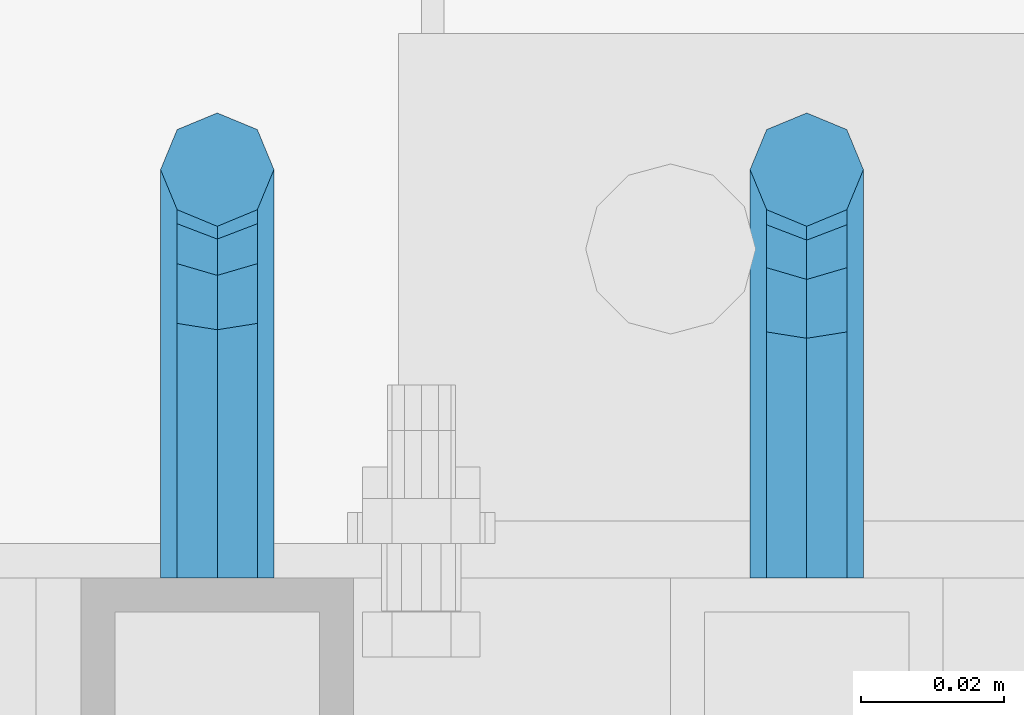
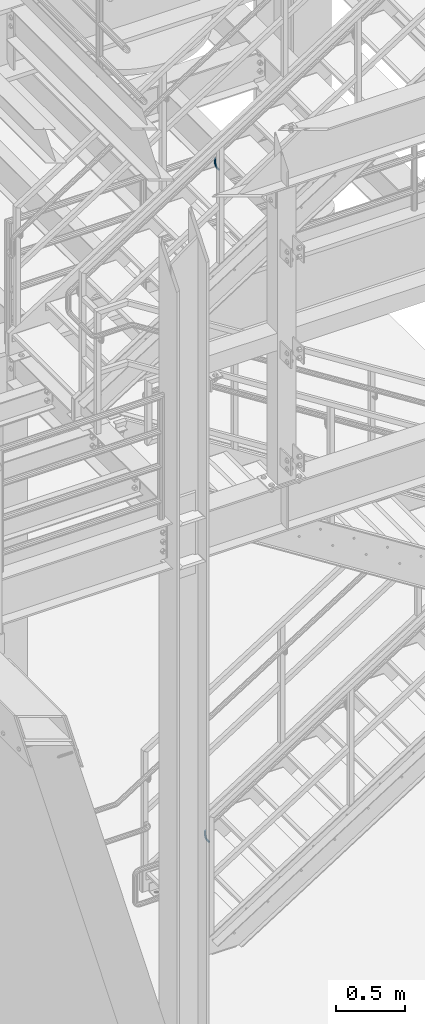
# One storey, part 1170 of 1876: 2 beams, 2 elements without a shape of their own.
"""IFC2X3 building model written with IfcOpenShell, lengths in millimetres."""

from ifc_helpers import new_model, si_unit, frame, origin_with_axes, place, context, subcontext, project, spatial, faceted_brep, material, type_object, element, aggregate, save


model = new_model("IFC2X3")

# Units and contexts
model_context = context("Model", 3, precision=1e-05, world=origin_with_axes())
body_context = subcontext(model_context, "Body", "Model", "MODEL_VIEW")
ifc_project = project(units=[si_unit("LENGTHUNIT", "METRE", prefix="MILLI"), si_unit("AREAUNIT", "SQUARE_METRE"), si_unit("VOLUMEUNIT", "CUBIC_METRE"), si_unit("MASSUNIT", "GRAM", prefix="KILO"), si_unit("TIMEUNIT", "SECOND"), si_unit("PLANEANGLEUNIT", "RADIAN"), si_unit("SOLIDANGLEUNIT", "STERADIAN"), si_unit("THERMODYNAMICTEMPERATUREUNIT", "DEGREE_CELSIUS"), si_unit("LUMINOUSINTENSITYUNIT", "LUMEN")], contexts=[model_context])

# Site, building, storey
site_placement = place(None, origin_with_axes())
site = spatial("IfcSite", under=ifc_project, at=site_placement, CompositionType="ELEMENT")
building_placement = place(site_placement, origin_with_axes())
building = spatial("IfcBuilding", under=site, at=building_placement, Name="Undefined", CompositionType="ELEMENT")
storey_placement = place(building_placement, origin_with_axes())
storey = spatial("IfcBuildingStorey", under=building, at=storey_placement, Name="Undefined", CompositionType="ELEMENT", Elevation=0.0)

# Assembly, beam
assembly_1_placement = place(storey_placement, origin_with_axes())
assembly_1 = element("IfcElementAssembly", 1, at=assembly_1_placement, inside=storey, Name="RAIL", AssemblyPlace="NOTDEFINED", PredefinedType="RIGID_FRAME")
ifc_material = material(Name="STEEL/A36")
beam_type = type_object("IfcBeamType", PredefinedType="NOTDEFINED")
beam_1_placement = place(assembly_1_placement, frame((2825.74999791169, -5715.00000114554, 6907.35688598217), z_axis=(1.0, 0.0, 0.0), x_axis=(0.0, 1.0, 0.0)))
beam_1 = element("IfcBeam", 2, at=beam_1_placement, type_object=beam_type, material=ifc_material, Name="BRACKET", context=body_context, shape_type="Brep", body=[
    faceted_brep([(0.0, -5.61266007566822, 5.61266007566883), (0.0, 0.0, 7.9375), (0.0, 5.61266007566822, 5.61266007566883), (0.0, 7.9375, 0.0), (0.0, 5.61266007566822, -5.61266007566883), (0.0, 0.0, -7.9375), (0.0, -5.61266007566822, -5.61266007566883), (0.0, -7.9375, 0.0), (23.8125, -5.61266007566883, -5.61266007566792), (23.8125, -7.9375, 0.0), (23.8125, -5.61266007566883, 5.61266007566792), (23.8125, 0.0, 7.9375), (23.8125, 5.61266007566883, 5.61266007566792), (23.8125, 7.9375, 0.0), (23.8125, 5.61266007566883, -5.61266007566792), (23.8125, 0.0, -7.9375), (36.5702095103998, 2.53766620105671, -7.9375), (38.7180815328556, -2.64775556579843, -5.61266007566792), (39.6077592547981, -4.79562758825341, 0.0), (38.7180815328556, -2.64775556579843, 5.61266007566792), (36.5702095103998, 2.53766620105671, 7.9375), (34.4223374879448, 7.72308796790821, 5.61266007566792), (33.5326597660023, 9.87095999036319, 0.0), (34.4223374879448, 7.72308796790821, -5.61266007566792), (43.4169233967659, 13.733078129113, -5.61266007566792), (47.3856733967659, 9.76432812911298, -7.9375), (41.773013321098, 15.3769882047818, 0.0), (43.4169233967659, 13.733078129113, 5.61266007566792), (47.3856733967659, 9.76432812911298, 7.9375), (51.3544233967659, 5.79557812911298, 5.61266007566792), (52.9983334724348, 4.15166805344415, 0.0), (51.3544233967659, 5.79557812911298, -5.61266007566792), (54.6123353248231, 20.5797920154801, -7.9375), (59.7977570916764, 18.4319199930251, -5.61266007566792), (49.4269135579698, 22.727664037935, -5.61266007566792), (47.2790415355148, 23.6173417598766, 0.0), (49.4269135579698, 22.727664037935, 5.61266007566792), (54.6123353248231, 20.5797920154801, 7.9375), (59.7977570916764, 18.4319199930251, 5.61266007566792), (61.9456291141314, 17.5422422710835, 0.0), (62.7626616015468, 33.3375015258789, -5.61266007566792), (65.0875015258789, 33.3375015258789, 0.0), (57.1500015258789, 33.3375015258789, -7.9375), (51.5373414502101, 33.3375015258789, -5.61266007566792), (49.2125015258789, 33.3375015258789, 0.0), (51.5373414502101, 33.3375015258789, 5.61266007566792), (57.1500015258789, 33.3375015258789, 7.9375), (62.7626616015468, 33.3375015258789, 5.61266007566792), (65.0875015258789, 66.3198431774908, 4.46561898570508e-10), (62.7626616015423, 69.8915357799633, 5.61266007614358), (57.1500015258725, 71.370979296531, 7.93750000048021), (51.5373414502064, 69.891535779956, 5.61266007613449), (49.2125015258789, 66.3198431774854, 4.38376446254551e-10), (51.5373414502164, 62.7481505750166, -5.61266007525228), (57.150001525888, 61.2687070584507, -7.937499999588), (62.7626616015532, 62.7481505750256, -5.61266007523955)], [[[0, 1, 2, 3, 4, 5, 6, 7]], [[7, 6, 8, 9]], [[0, 7, 9, 10]], [[1, 0, 10, 11]], [[2, 1, 11, 12]], [[3, 2, 12, 13]], [[4, 3, 13, 14]], [[5, 4, 14, 15]], [[6, 5, 15, 8]], [[8, 15, 16, 17]], [[9, 8, 17, 18]], [[10, 9, 18, 19]], [[11, 10, 19, 20]], [[12, 11, 20, 21]], [[13, 12, 21, 22]], [[14, 13, 22, 23]], [[15, 14, 23, 16]], [[23, 24, 25, 16]], [[22, 26, 24, 23]], [[21, 27, 26, 22]], [[20, 28, 27, 21]], [[19, 29, 28, 20]], [[18, 30, 29, 19]], [[17, 31, 30, 18]], [[16, 25, 31, 17]], [[25, 32, 33, 31]], [[24, 34, 32, 25]], [[26, 35, 34, 24]], [[27, 36, 35, 26]], [[28, 37, 36, 27]], [[29, 38, 37, 28]], [[30, 39, 38, 29]], [[31, 33, 39, 30]], [[33, 40, 41, 39]], [[32, 42, 40, 33]], [[34, 43, 42, 32]], [[35, 44, 43, 34]], [[36, 45, 44, 35]], [[37, 46, 45, 36]], [[38, 47, 46, 37]], [[39, 41, 47, 38]], [[47, 41, 48, 49]], [[46, 47, 49, 50]], [[45, 46, 50, 51]], [[44, 45, 51, 52]], [[43, 44, 52, 53]], [[42, 43, 53, 54]], [[40, 42, 54, 55]], [[41, 40, 55, 48]], [[54, 53, 52, 51, 50, 49, 48, 55]]]),
])
aggregate(assembly_1, [beam_1])

assembly_2_placement = place(storey_placement, origin_with_axes())
assembly_2 = element("IfcElementAssembly", 3, at=assembly_2_placement, inside=storey, Name="RAIL", AssemblyPlace="NOTDEFINED", PredefinedType="RIGID_FRAME")
beam_2_placement = place(assembly_2_placement, frame((2743.20006242452, -5715.00000114554, 1002.75261336977), z_axis=(1.0, 0.0, 0.0), x_axis=(0.0, 1.0, 0.0)))
beam_2 = element("IfcBeam", 4, at=beam_2_placement, type_object=beam_type, material=ifc_material, Name="BRACKET", context=body_context, shape_type="Brep", body=[
    faceted_brep([(0.0, -5.61266007566822, 5.61266007566883), (0.0, 0.0, 7.9375), (0.0, 5.61266007566822, 5.61266007566883), (0.0, 7.9375, 0.0), (0.0, 5.61266007566822, -5.61266007566883), (0.0, 0.0, -7.9375), (0.0, -5.61266007566822, -5.61266007566883), (0.0, -7.9375, 0.0), (25.7500019073486, -5.6126600756694, -5.61266007566974), (25.7500019073486, -7.93750000000102, -1.81898940354586e-12), (25.7500019073486, -5.61266007566837, 5.61266007566746), (25.7500019073486, 6.82121026329696e-13, 7.93750000000045), (25.7500019073486, 5.6126600756694, 5.61266007566928), (25.7500019073486, 7.93750000000102, 9.09494701772928e-13), (25.7500019073486, 5.61266007566837, -5.61266007566837), (25.7500019073486, -6.82121026329696e-13, -7.93750000000091), (37.7662607879083, 2.39017891888352, -7.93750166859718), (39.9141330299508, -2.79524175511915, -5.61265950959933), (40.803811282025, -4.94311113920139, 1.49169682117645e-06), (39.9141340902152, -2.79523647837323, 5.6126606417356), (37.7662622873477, 2.39018638132939, 7.937498331401), (35.6183900453052, 7.57560705533251, 5.61265617240315), (34.728711793231, 9.7234764394143, -4.82889299746603e-06), (35.6183889850417, 7.57560177858613, -5.61266397893178), (43.9844035873093, 13.1655940203409, -5.61266788133162), (47.9531531815637, 9.19684280310457, -7.93750642036139), (42.3404944911981, 14.8095070346781, -8.37947573018027e-06), (43.9844055464218, 13.1655998976785, 5.6126522700024), (47.9531559521674, 9.19685111491481, 7.93749357963588), (51.9219055464218, 5.22809989767848, 5.61265504060611), (53.565814642534, 3.58418688334177, -4.46125068265246e-06), (51.9219035873093, 5.2280940203409, -5.61266511072881), (54.7598170657875, 19.3837351967577, -7.93751353188054), (59.9452393627726, 17.2358645776962, -5.61267349341051), (49.5743958290659, 21.5316086226071, -5.61267372168732), (47.4265250864628, 22.4212897326429, -1.36932976602111e-05), (49.5743983887696, 21.5316153987928, 5.61264642964761), (54.7598206857547, 19.3837447797314, 7.93748646811673), (59.9452419224763, 17.235871353882, 5.61264665792351), (62.0931126650794, 16.3461902438462, -1.33704661493539e-05), (62.7626602162454, 31.3999957002966, -5.61268338145874), (65.0875015258789, 31.3999996185225, -2.19204903260106e-05), (57.1499995667664, 31.399994077316, -7.93752192048851), (51.5373400649087, 31.3999957002989, -5.61268061085502), (49.2125015258789, 31.3999996185239, -1.99613778022467e-05), (51.5373428355124, 31.4000035367485, 5.61263954047809), (57.1500034849914, 31.4000051597295, 7.93747807950785), (62.7626629868482, 31.4000035367467, 5.61263676987437), (65.0875015258789, 66.3398661827996, -4.63121787106502e-05), (62.7626620592855, 69.9005606306541, 5.6126108200142), (57.1500021229667, 71.3754489730973, 7.93745017245874), (51.5373419079488, 69.9005612114365, 5.61261173549065), (49.2125015258789, 66.3398666704393, -4.55435210824362e-05), (51.5373408209025, 62.7791718437898, -5.61270327280181), (57.1500005856506, 61.3042833925019, -7.93754279681616), (62.7626609722383, 62.779171045318, -5.61270453141788)], [[[0, 1, 2, 3, 4, 5, 6, 7]], [[7, 6, 8, 9]], [[0, 7, 9, 10]], [[1, 0, 10, 11]], [[2, 1, 11, 12]], [[3, 2, 12, 13]], [[4, 3, 13, 14]], [[5, 4, 14, 15]], [[6, 5, 15, 8]], [[8, 15, 16, 17]], [[9, 8, 17, 18]], [[10, 9, 18, 19]], [[11, 10, 19, 20]], [[12, 11, 20, 21]], [[13, 12, 21, 22]], [[14, 13, 22, 23]], [[15, 14, 23, 16]], [[23, 24, 25, 16]], [[22, 26, 24, 23]], [[21, 27, 26, 22]], [[20, 28, 27, 21]], [[19, 29, 28, 20]], [[18, 30, 29, 19]], [[17, 31, 30, 18]], [[16, 25, 31, 17]], [[25, 32, 33, 31]], [[24, 34, 32, 25]], [[26, 35, 34, 24]], [[27, 36, 35, 26]], [[28, 37, 36, 27]], [[29, 38, 37, 28]], [[30, 39, 38, 29]], [[31, 33, 39, 30]], [[33, 40, 41, 39]], [[32, 42, 40, 33]], [[34, 43, 42, 32]], [[35, 44, 43, 34]], [[36, 45, 44, 35]], [[37, 46, 45, 36]], [[38, 47, 46, 37]], [[39, 41, 47, 38]], [[47, 41, 48, 49]], [[46, 47, 49, 50]], [[45, 46, 50, 51]], [[44, 45, 51, 52]], [[43, 44, 52, 53]], [[42, 43, 53, 54]], [[40, 42, 54, 55]], [[41, 40, 55, 48]], [[54, 53, 52, 51, 50, 49, 48, 55]]]),
])
aggregate(assembly_2, [beam_2])

save(model, "model.ifc")
